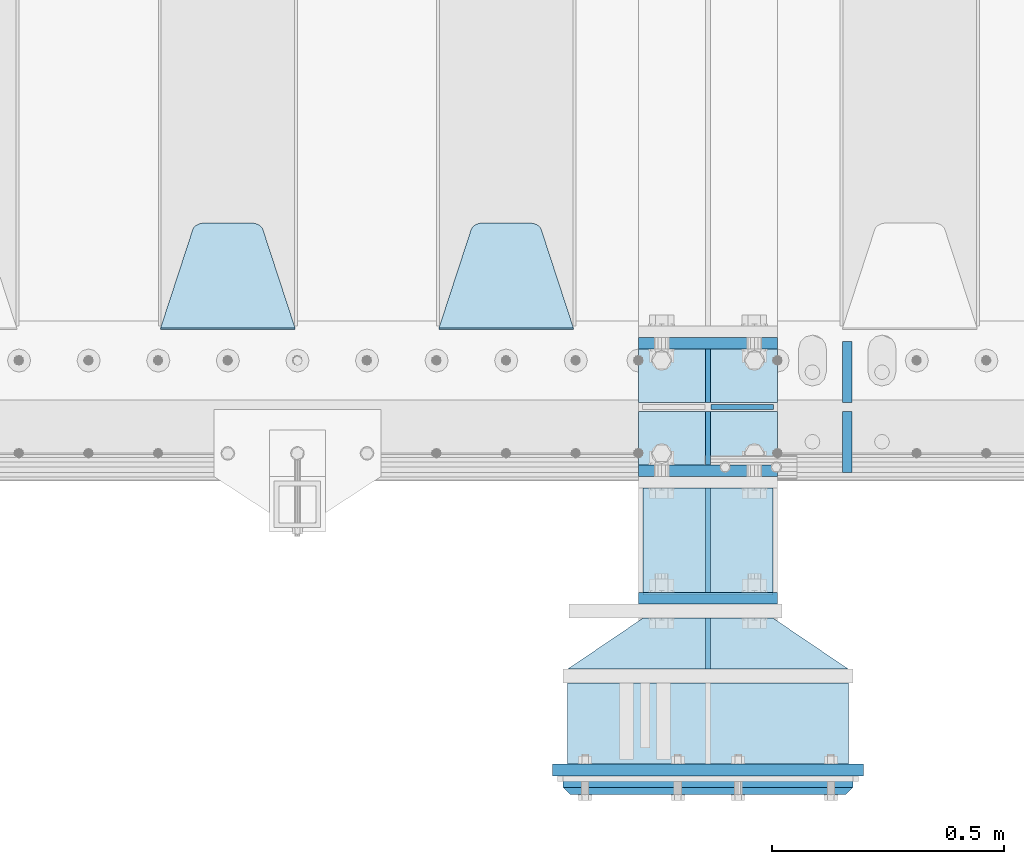
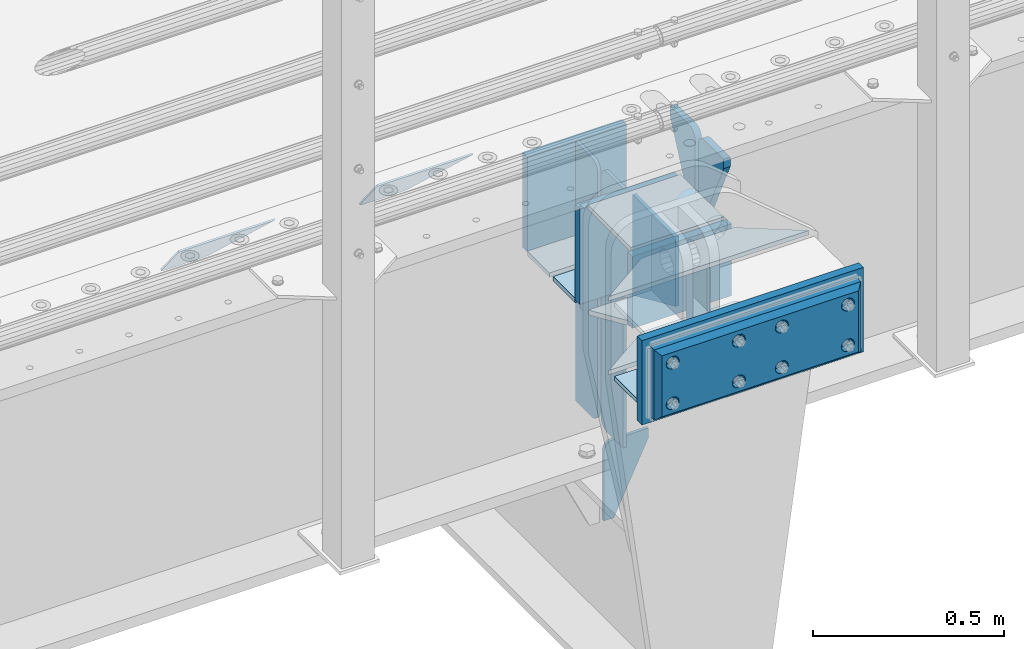
# One storey, part 208 of 242: 23 plates.
"""IFC2X3 building model written with IfcOpenShell, lengths in millimetres."""

from ifc_helpers import new_model, si_unit, frame, origin_with_axes, place, context, subcontext, project, spatial, faceted_brep, material, type_object, element, save


model = new_model("IFC2X3")

# Units and contexts
model_context = context("Model", 3, precision=1e-05, world=origin_with_axes())
body_context = subcontext(model_context, "Body", "Model", "MODEL_VIEW")
ifc_project = project(units=[si_unit("LENGTHUNIT", "METRE", prefix="MILLI"), si_unit("AREAUNIT", "SQUARE_METRE"), si_unit("VOLUMEUNIT", "CUBIC_METRE"), si_unit("MASSUNIT", "GRAM", prefix="KILO"), si_unit("TIMEUNIT", "SECOND"), si_unit("PLANEANGLEUNIT", "RADIAN"), si_unit("SOLIDANGLEUNIT", "STERADIAN"), si_unit("THERMODYNAMICTEMPERATUREUNIT", "DEGREE_CELSIUS"), si_unit("LUMINOUSINTENSITYUNIT", "LUMEN")], contexts=[model_context])

# Site, building, storey
site_placement = place(None, origin_with_axes())
site = spatial("IfcSite", under=ifc_project, at=site_placement, CompositionType="ELEMENT")
building_placement = place(site_placement, origin_with_axes())
building = spatial("IfcBuilding", under=site, at=building_placement, Name="Standard", CompositionType="ELEMENT")
storey_placement = place(building_placement, origin_with_axes())
storey = spatial("IfcBuildingStorey", under=building, at=storey_placement, Name="Undefined", CompositionType="ELEMENT", Elevation=0.0)

# Plates
ifc_material_1 = material(Name="STEEL/S355N")
plate_type_1 = type_object("IfcPlateType", PredefinedType="NOTDEFINED")
plate_1_placement = place(storey_placement, frame((-28554.9999999412, -24175.0000000349, -17.0000182225592), z_axis=(0.0, -1.0, 0.0), x_axis=(1.0, 0.0, 0.0)))
element("IfcPlate", 1, at=plate_1_placement, inside=storey, type_object=plate_type_1, material=ifc_material_1, context=body_context, shape_type="Brep", body=[
    faceted_brep([(0.0, -7.0, 0.0), (0.0, -7.0, 225.0), (0.0, 7.0, 225.0), (0.0, 7.0, 0.0), (280.0, -7.0, 225.0), (280.0, 7.0, 225.0), (280.0, -7.0, 0.0), (280.0, 7.0, 0.0)], [[[0, 1, 2, 3]], [[1, 4, 5, 2]], [[4, 6, 7, 5]], [[6, 0, 3, 7]], [[5, 7, 3, 2]], [[6, 4, 1, 0]]]),
])
plate_type_2 = type_object("IfcPlateType", PredefinedType="NOTDEFINED")
plate_2_placement = place(storey_placement, frame((-28408.4999999409, -24000.0000000349, -925.000018222557), z_axis=(0.0, 0.0, -1.0), x_axis=(1.0, 0.0, 0.0)))
element("IfcPlate", 2, at=plate_2_placement, inside=storey, type_object=plate_type_2, material=ifc_material_1, context=body_context, shape_type="Brep", body=[
    faceted_brep([(0.0, -5.0, 27.0), (0.0, -5.0, 250.0), (0.0, 5.0, 250.0), (0.0, 5.0, 27.0), (30.0, -5.0, 250.0), (30.0, 5.0, 250.0), (135.0, -5.0, 30.0), (135.0, 5.0, 30.0), (135.0, -5.0, 0.0), (135.0, 5.0, 0.0), (27.0, -5.0, 0.0), (27.0, 5.0, 0.0), (22.3114992029914, -5.0, 0.410190668670339), (22.3114992029914, 5.0, 0.410190668670339), (17.7654561302079, -5.0, 1.62829923878041), (17.7654561302079, 5.0, 1.62829923878041), (13.5, -5.0, 3.61731409782021), (13.5, 5.0, 3.61731409782021), (9.64473453846222, -5.0, 6.31680003578765), (9.64473453846222, 5.0, 6.31680003578765), (6.31680003578731, -5.0, 9.64473453846347), (6.31680003578731, 5.0, 9.64473453846347), (3.61731409782078, -5.0, 13.5), (3.61731409782078, 5.0, 13.5), (1.62829923877871, -5.0, 17.765456130207), (1.62829923877871, 5.0, 17.765456130207), (0.410190668670111, -5.0, 22.3114992029929), (0.410190668670111, 5.0, 22.3114992029929)], [[[0, 1, 2, 3]], [[1, 4, 5, 2]], [[4, 6, 7, 5]], [[6, 8, 9, 7]], [[8, 10, 11, 9]], [[10, 12, 13, 11]], [[12, 14, 15, 13]], [[14, 16, 17, 15]], [[16, 18, 19, 17]], [[18, 20, 21, 19]], [[20, 22, 23, 21]], [[22, 24, 25, 23]], [[24, 26, 27, 25]], [[26, 0, 3, 27]], [[5, 7, 9, 11, 13, 15, 17, 19, 21, 23, 25, 27, 3, 2]], [[26, 24, 22, 20, 18, 16, 14, 12, 10, 8, 6, 4, 1, 0]]]),
])
plate_type_3 = type_object("IfcPlateType", PredefinedType="NOTDEFINED")
plate_3_placement = place(storey_placement, frame((-28554.9999999412, -24177.842969296, -352.396699063478), z_axis=(0.0, -0.913811548702731, 0.406138465867881), x_axis=(1.0, 0.0, 0.0)))
element("IfcPlate", 3, at=plate_3_placement, inside=storey, type_object=plate_type_3, material=ifc_material_1, context=body_context, shape_type="Brep", body=[
    faceted_brep([(0.0, -7.0, 0.0), (0.0, -6.99999999999909, 246.221450805666), (0.0, 6.99999999999909, 246.22145080566), (0.0, 7.0, 0.0), (280.0, -6.99999999999909, 246.221450805666), (280.0, 6.99999999999909, 246.22145080566), (280.0, -7.0, 0.0), (280.0, 7.0, 0.0)], [[[0, 1, 2, 3]], [[1, 4, 5, 2]], [[4, 6, 7, 5]], [[6, 0, 3, 7]], [[5, 7, 3, 2]], [[6, 4, 1, 0]]]),
])
ifc_material_2 = material()
plate_type_4 = type_object("IfcPlateType", PredefinedType="NOTDEFINED")
plate_4_placement = place(storey_placement, frame((-28112.4999999399, -24595.000000035, -253.000018222559), z_axis=(0.0, -1.0, 0.0), x_axis=(-1.0, 0.0, 0.0)))
element("IfcPlate", 4, at=plate_4_placement, inside=storey, type_object=plate_type_4, material=ifc_material_2, context=body_context, shape_type="Brep", body=[
    faceted_brep([(0.0, -7.0, 0.0), (0.0, -7.0, 175.0), (0.0, 7.0, 175.0), (0.0, 7.0, 0.0), (605.0, -7.0, 175.0), (605.0, 7.0, 175.0), (605.0, -7.0, 0.0), (605.0, 7.0, 0.0)], [[[0, 1, 2, 3]], [[1, 4, 5, 2]], [[4, 6, 7, 5]], [[6, 0, 3, 7]], [[5, 7, 3, 2]], [[6, 4, 1, 0]]]),
])
plate_type_5 = type_object("IfcPlateType", PredefinedType="NOTDEFINED")
for number, where, z_axis, x_axis in (
    (5, (-28565.0, -23862.5, -340.0), (0.0, 0.0, 1.0), (1.0, 0.0, 0.0)),
    (6, (-28565.0, -24137.5, -340.0), (0.0, 0.0, 1.0), (1.0, 0.0, 0.0)),
):
    element("IfcPlate", number, at=place(storey_placement, frame(where, z_axis=z_axis, x_axis=x_axis)), inside=storey, type_object=plate_type_5, material=ifc_material_1, context=body_context, shape_type="Brep", body=[
        faceted_brep([(0.0, -12.5, 0.0), (0.0, -12.5, 305.0), (0.0, 12.5, 305.0), (0.0, 12.5, 0.0), (300.0, -12.5, 305.0), (300.0, 12.5, 305.0), (300.0, -12.5, 0.0), (300.0, 12.5, 0.0)], [[[0, 1, 2, 3]], [[1, 4, 5, 2]], [[4, 6, 7, 5]], [[6, 0, 3, 7]], [[5, 7, 3, 2]], [[6, 4, 1, 0]]]),
    ])
plate_type_6 = type_object("IfcPlateType", PredefinedType="NOTDEFINED")
plate_5_placement = place(storey_placement, frame((-28414.9999999407, -24565.0000000349, -24.0000182225592), z_axis=(0.0, 0.0, -1.0), x_axis=(0.0, 1.0, 0.0)))
element("IfcPlate", 7, at=plate_5_placement, inside=storey, type_object=plate_type_6, material=ifc_material_1, context=body_context, shape_type="Brep", body=[
    faceted_brep([(0.0, -5.0, 0.0), (0.0, -5.0, 222.0), (0.0, 5.0, 222.0), (0.0, 5.0, 0.0), (110.0, -5.0, 222.0), (110.0, 5.0, 222.0), (110.0, -5.0, 0.0), (110.0, 5.0, 0.0)], [[[0, 1, 2, 3]], [[1, 4, 5, 2]], [[4, 6, 7, 5]], [[6, 0, 3, 7]], [[5, 7, 3, 2]], [[6, 4, 1, 0]]]),
])
plate_type_7 = type_object("IfcPlateType", PredefinedType="NOTDEFINED")
for number, where, z_axis, x_axis in (
    (8, (-28112.4999999399, -24565.000000035, -253.000018222559), (-0.560566412034006, -0.828109472050236, 0.0), (-0.828109472050236, 0.560566412034007, 0.0)),
    (9, (-28112.4999999399, -24565.000000035, -17.0000182225592), (-0.560566412034006, -0.828109472050236, 0.0), (-0.828109472050236, 0.560566412034007, 0.0)),
):
    element("IfcPlate", number, at=place(storey_placement, frame(where, z_axis=z_axis, x_axis=x_axis)), inside=storey, type_object=plate_type_7, material=ifc_material_1, context=body_context, shape_type="Brep", body=[
        faceted_brep([(0.0, -7.0, 0.0), (501.006225585945, -7.0, 339.142669677734), (501.006225585945, 7.0, 339.142669677734), (0.0, 7.0, 0.0), (428.100738525391, -7.0, 156.958602905273), (428.100738525391, 7.0, 156.958602905273), (196.230087280281, -7.0, -4.00177668780088e-11), (196.230087280281, 7.0, -4.00177668780088e-11)], [[[0, 1, 2, 3]], [[1, 4, 5, 2]], [[4, 6, 7, 5]], [[6, 0, 3, 7]], [[5, 7, 3, 2]], [[6, 4, 1, 0]]]),
    ])
plate_type_8 = type_object("IfcPlateType", PredefinedType="NOTDEFINED")
plate_6_placement = place(storey_placement, frame((-28564.9999999411, -24412.5000000349, -250.000018222559), z_axis=(0.0, 0.0, 1.0), x_axis=(1.0, 0.0, 0.0)))
element("IfcPlate", 10, at=plate_6_placement, inside=storey, type_object=plate_type_8, material=ifc_material_1, context=body_context, shape_type="Brep", body=[
    faceted_brep([(0.0, -12.5, 0.0), (0.0, -12.5, 230.0), (0.0, 12.5, 230.0), (0.0, 12.5, 0.0), (300.0, -12.5, 230.0), (300.0, 12.5, 230.0), (300.0, -12.5, 0.0), (300.0, 12.5, 0.0)], [[[0, 1, 2, 3]], [[1, 4, 5, 2]], [[4, 6, 7, 5]], [[6, 0, 3, 7]], [[5, 7, 3, 2]], [[6, 4, 1, 0]]]),
])
ifc_material_3 = material()
plate_type_9 = type_object("IfcPlateType", PredefinedType="NOTDEFINED")
plate_7_placement = place(storey_placement, frame((-28102.4999999398, -24815.000000035, -22.5000182225592), z_axis=(0.0, 0.0, -1.0), x_axis=(-1.0, 0.0, 0.0)))
element("IfcPlate", 11, at=plate_7_placement, inside=storey, type_object=plate_type_9, material=ifc_material_3, context=body_context, shape_type="Brep", body=[
    faceted_brep([(0.0, -5.0, 0.0), (15.0, -20.0, 15.0), (15.0, -20.0, 210.0), (0.0, -5.0, 225.0), (625.0, -5.0, 225.0), (610.0, -20.0, 210.0), (610.0, -20.0, 15.0), (625.0, -5.0, 0.0), (625.0, 15.0, 0.0), (620.0, 20.0, 5.0), (620.0, 20.0, 220.0), (625.0, 15.0, 225.0), (0.0, 15.0, 225.0), (5.0, 20.0, 220.0), (5.0, 20.0, 5.0), (0.0, 15.0, 0.0), (30.179491924413, 5.00000000001455, 37.4999999999982), (37.5000000001019, 5.00000000001455, 30.1794919243094), (47.5000000001019, 5.00000000001455, 27.4999999999982), (57.5000000001019, 5.00000000001455, 30.1794919243094), (64.8205080757907, 5.00000000001455, 37.4999999999982), (67.5000000001019, 5.00000000001455, 47.4999999999982), (64.8205080757907, 5.00000000001455, 57.4999999999982), (57.5000000001019, 5.00000000001455, 64.8205080756869), (47.5000000001019, 5.00000000001455, 67.4999999999982), (37.5000000001019, 5.00000000001455, 64.820508075687), (30.179491924413, 5.00000000001455, 57.4999999999982), (27.5000000001019, 5.00000000001455, 47.4999999999982), (37.5000000001019, -20.0, 30.1794919243094), (30.179491924413, -20.0, 37.4999999999982), (47.5000000001019, -20.0, 27.4999999999982), (57.5000000001019, -20.0, 30.1794919243094), (64.8205080757907, -20.0, 37.4999999999982), (67.5000000001019, -20.0, 47.4999999999982), (64.8205080757907, -20.0, 57.4999999999982), (57.5000000001019, -20.0, 64.8205080756869), (47.5000000001019, -20.0, 67.4999999999982), (37.5000000001019, -20.0, 64.820508075687), (30.179491924413, -20.0, 57.4999999999982), (27.5000000001019, -20.0, 47.4999999999982), (230.179491924951, 5.00000000008004, 37.4999999999982), (237.50000000064, 5.00000000008004, 30.1794919243094), (247.50000000064, 5.00000000008004, 27.4999999999982), (257.50000000064, 5.00000000008004, 30.1794919243094), (264.820508076329, 5.00000000008004, 37.4999999999982), (267.50000000064, 5.00000000008004, 47.4999999999982), (264.820508076329, 5.00000000008004, 57.4999999999982), (257.50000000064, 5.00000000008004, 64.8205080756869), (247.50000000064, 5.00000000008004, 67.4999999999982), (237.50000000064, 5.00000000008004, 64.820508075687), (230.179491924951, 5.00000000008004, 57.4999999999982), (227.50000000064, 5.00000000008004, 47.4999999999982), (230.179491924951, -20.0, 37.4999999999982), (227.50000000064, -20.0, 47.4999999999982), (237.50000000064, -20.0, 30.1794919243094), (247.50000000064, -20.0, 27.4999999999982), (257.50000000064, -20.0, 30.1794919243094), (264.820508076329, -20.0, 37.4999999999982), (267.50000000064, -20.0, 47.4999999999982), (264.820508076329, -20.0, 57.4999999999982), (257.50000000064, -20.0, 64.8205080756869), (247.50000000064, -20.0, 67.4999999999982), (237.50000000064, -20.0, 64.820508075687), (230.179491924951, -20.0, 57.4999999999982), (560.179491925839, 5.0000000001819, 37.4999999999982), (567.500000001528, 5.0000000001819, 30.1794919243094), (577.500000001528, 5.0000000001819, 27.4999999999982), (587.500000001528, 5.0000000001819, 30.1794919243094), (594.820508077217, 5.0000000001819, 37.4999999999982), (597.500000001528, 5.0000000001819, 47.4999999999982), (594.820508077217, 5.0000000001819, 57.4999999999982), (587.500000001528, 5.0000000001819, 64.8205080756869), (577.500000001528, 5.0000000001819, 67.4999999999982), (567.500000001528, 5.0000000001819, 64.820508075687), (560.179491925839, 5.0000000001819, 57.4999999999982), (557.500000001528, 5.0000000001819, 47.4999999999982), (560.179491925839, -20.0, 37.4999999999982), (557.500000001528, -20.0, 47.4999999999982), (567.500000001528, -20.0, 30.1794919243094), (577.500000001528, -20.0, 27.4999999999982), (587.500000001528, -20.0, 30.1794919243094), (594.820508077217, -20.0, 37.4999999999982), (597.500000001528, -20.0, 47.4999999999982), (594.820508077217, -20.0, 57.4999999999982), (587.500000001528, -20.0, 64.8205080756869), (577.500000001528, -20.0, 67.4999999999982), (567.500000001528, -20.0, 64.820508075687), (560.179491925839, -20.0, 57.4999999999982), (560.179491925839, 5.0000000001819, 167.499999999998), (567.500000001528, 5.0000000001819, 160.179491924309), (577.500000001528, 5.0000000001819, 157.499999999998), (587.500000001528, 5.0000000001819, 160.179491924309), (594.820508077217, 5.0000000001819, 167.499999999998), (597.500000001528, 5.0000000001819, 177.499999999998), (594.820508077217, 5.0000000001819, 187.499999999998), (587.500000001528, 5.0000000001819, 194.820508075687), (577.500000001528, 5.0000000001819, 197.499999999998), (567.500000001528, 5.0000000001819, 194.820508075687), (560.179491925839, 5.0000000001819, 187.499999999998), (557.500000001528, 5.0000000001819, 177.499999999998), (560.179491925839, -20.0, 167.499999999998), (557.500000001528, -20.0, 177.499999999998), (567.500000001528, -20.0, 160.179491924309), (577.500000001528, -20.0, 157.499999999998), (587.500000001528, -20.0, 160.179491924309), (594.820508077217, -20.0, 167.499999999998), (597.500000001528, -20.0, 177.499999999998), (594.820508077217, -20.0, 187.499999999998), (587.500000001528, -20.0, 194.820508075687), (577.500000001528, -20.0, 197.499999999998), (567.500000001528, -20.0, 194.820508075687), (560.179491925839, -20.0, 187.499999999998), (230.179491924951, 5.00000000008004, 167.499999999998), (237.50000000064, 5.00000000008004, 160.179491924309), (247.50000000064, 5.00000000008004, 157.499999999998), (257.50000000064, 5.00000000008004, 160.179491924309), (264.820508076329, 5.00000000008004, 167.499999999998), (267.50000000064, 5.00000000008004, 177.499999999998), (264.820508076329, 5.00000000008004, 187.499999999998), (257.50000000064, 5.00000000008004, 194.820508075687), (247.50000000064, 5.00000000008004, 197.499999999998), (237.50000000064, 5.00000000008004, 194.820508075687), (230.179491924951, 5.00000000008004, 187.499999999998), (227.50000000064, 5.00000000008004, 177.499999999998), (230.179491924951, -20.0, 167.499999999998), (227.50000000064, -20.0, 177.499999999998), (237.50000000064, -20.0, 160.179491924309), (247.50000000064, -20.0, 157.499999999998), (257.50000000064, -20.0, 160.179491924309), (264.820508076329, -20.0, 167.499999999998), (267.50000000064, -20.0, 177.499999999998), (264.820508076329, -20.0, 187.499999999998), (257.50000000064, -20.0, 194.820508075687), (247.50000000064, -20.0, 197.499999999998), (237.50000000064, -20.0, 194.820508075687), (230.179491924951, -20.0, 187.499999999998), (30.179491924413, 5.00000000001455, 167.499999999998), (37.5000000001019, 5.00000000001455, 160.179491924309), (47.5000000001019, 5.00000000001455, 157.499999999998), (57.5000000001019, 5.00000000001455, 160.179491924309), (64.8205080757907, 5.00000000001455, 167.499999999998), (67.5000000001019, 5.00000000001455, 177.499999999998), (64.8205080757907, 5.00000000001455, 187.499999999998), (57.5000000001019, 5.00000000001455, 194.820508075687), (47.5000000001019, 5.00000000001455, 197.499999999998), (37.5000000001019, 5.00000000001455, 194.820508075687), (30.179491924413, 5.00000000001455, 187.499999999998), (27.5000000001019, 5.00000000001455, 177.499999999998), (30.179491924413, -20.0, 167.499999999998), (27.5000000001019, -20.0, 177.499999999998), (37.5000000001019, -20.0, 160.179491924309), (47.5000000001019, -20.0, 157.499999999998), (57.5000000001019, -20.0, 160.179491924309), (64.8205080757907, -20.0, 167.499999999998), (67.5000000001019, -20.0, 177.499999999998), (64.8205080757907, -20.0, 187.499999999998), (57.5000000001019, -20.0, 194.820508075687), (47.5000000001019, -20.0, 197.499999999998), (37.5000000001019, -20.0, 194.820508075687), (30.179491924413, -20.0, 187.499999999998), (360.179491925301, 5.00000000012005, 167.499999999998), (367.50000000099, 5.00000000012005, 160.179491924309), (377.50000000099, 5.00000000012005, 157.499999999998), (387.50000000099, 5.00000000012005, 160.179491924309), (394.820508076678, 5.00000000012005, 167.499999999998), (397.50000000099, 5.00000000012005, 177.499999999998), (394.820508076678, 5.00000000012005, 187.499999999998), (387.50000000099, 5.00000000012005, 194.820508075687), (377.50000000099, 5.00000000012005, 197.499999999998), (367.50000000099, 5.00000000012005, 194.820508075687), (360.179491925301, 5.00000000012005, 187.499999999998), (357.50000000099, 5.00000000012005, 177.499999999998), (360.179491925301, -20.0, 167.499999999998), (357.50000000099, -20.0, 177.499999999998), (367.50000000099, -20.0, 160.179491924309), (377.50000000099, -20.0, 157.499999999998), (387.50000000099, -20.0, 160.179491924309), (394.820508076678, -20.0, 167.499999999998), (397.50000000099, -20.0, 177.499999999998), (394.820508076678, -20.0, 187.499999999998), (387.50000000099, -20.0, 194.820508075687), (377.50000000099, -20.0, 197.499999999998), (367.50000000099, -20.0, 194.820508075687), (360.179491925301, -20.0, 187.499999999998), (360.179491925301, 5.00000000012005, 37.4999999999982), (367.50000000099, 5.00000000012005, 30.1794919243094), (377.50000000099, 5.00000000012005, 27.4999999999982), (387.50000000099, 5.00000000012005, 30.1794919243094), (394.820508076678, 5.00000000012005, 37.4999999999982), (397.50000000099, 5.00000000012005, 47.4999999999982), (394.820508076678, 5.00000000012005, 57.4999999999982), (387.50000000099, 5.00000000012005, 64.8205080756869), (377.50000000099, 5.00000000012005, 67.4999999999982), (367.50000000099, 5.00000000012005, 64.820508075687), (360.179491925301, 5.00000000012005, 57.4999999999982), (357.50000000099, 5.00000000012005, 47.4999999999982), (360.179491925301, -20.0, 37.4999999999982), (357.50000000099, -20.0, 47.4999999999982), (367.50000000099, -20.0, 30.1794919243094), (377.50000000099, -20.0, 27.4999999999982), (387.50000000099, -20.0, 30.1794919243094), (394.820508076678, -20.0, 37.4999999999982), (397.50000000099, -20.0, 47.4999999999982), (394.820508076678, -20.0, 57.4999999999982), (387.50000000099, -20.0, 64.8205080756869), (377.50000000099, -20.0, 67.4999999999982), (367.50000000099, -20.0, 64.820508075687), (360.179491925301, -20.0, 57.4999999999982)], [[[0, 1, 2, 3]], [[4, 5, 6, 7]], [[8, 9, 10, 11]], [[12, 13, 14, 15]], [[15, 14, 9, 8]], [[5, 4, 3, 2]], [[13, 12, 11, 10]], [[7, 6, 1, 0]], [[16, 17, 18, 19, 20, 21, 22, 23, 24, 25, 26, 27]], [[28, 17, 16, 29]], [[30, 18, 17, 28]], [[31, 19, 18, 30]], [[32, 20, 19, 31]], [[33, 21, 20, 32]], [[34, 22, 21, 33]], [[35, 23, 22, 34]], [[36, 24, 23, 35]], [[37, 25, 24, 36]], [[38, 26, 25, 37]], [[39, 27, 26, 38]], [[29, 16, 27, 39]], [[11, 12, 3, 4]], [[8, 11, 4, 7]], [[7, 0, 15, 8]], [[14, 13, 10, 9]], [[12, 15, 0, 3]], [[40, 41, 42, 43, 44, 45, 46, 47, 48, 49, 50, 51]], [[52, 40, 51, 53]], [[54, 41, 40, 52]], [[55, 42, 41, 54]], [[56, 43, 42, 55]], [[57, 44, 43, 56]], [[58, 45, 44, 57]], [[59, 46, 45, 58]], [[60, 47, 46, 59]], [[61, 48, 47, 60]], [[62, 49, 48, 61]], [[63, 50, 49, 62]], [[53, 51, 50, 63]], [[64, 65, 66, 67, 68, 69, 70, 71, 72, 73, 74, 75]], [[76, 64, 75, 77]], [[78, 65, 64, 76]], [[79, 66, 65, 78]], [[80, 67, 66, 79]], [[81, 68, 67, 80]], [[82, 69, 68, 81]], [[83, 70, 69, 82]], [[84, 71, 70, 83]], [[85, 72, 71, 84]], [[86, 73, 72, 85]], [[87, 74, 73, 86]], [[77, 75, 74, 87]], [[88, 89, 90, 91, 92, 93, 94, 95, 96, 97, 98, 99]], [[100, 88, 99, 101]], [[102, 89, 88, 100]], [[103, 90, 89, 102]], [[104, 91, 90, 103]], [[105, 92, 91, 104]], [[106, 93, 92, 105]], [[107, 94, 93, 106]], [[108, 95, 94, 107]], [[109, 96, 95, 108]], [[110, 97, 96, 109]], [[111, 98, 97, 110]], [[101, 99, 98, 111]], [[112, 113, 114, 115, 116, 117, 118, 119, 120, 121, 122, 123]], [[124, 112, 123, 125]], [[126, 113, 112, 124]], [[127, 114, 113, 126]], [[128, 115, 114, 127]], [[129, 116, 115, 128]], [[130, 117, 116, 129]], [[131, 118, 117, 130]], [[132, 119, 118, 131]], [[133, 120, 119, 132]], [[134, 121, 120, 133]], [[135, 122, 121, 134]], [[125, 123, 122, 135]], [[136, 137, 138, 139, 140, 141, 142, 143, 144, 145, 146, 147]], [[148, 136, 147, 149]], [[150, 137, 136, 148]], [[151, 138, 137, 150]], [[152, 139, 138, 151]], [[153, 140, 139, 152]], [[154, 141, 140, 153]], [[155, 142, 141, 154]], [[156, 143, 142, 155]], [[157, 144, 143, 156]], [[158, 145, 144, 157]], [[159, 146, 145, 158]], [[149, 147, 146, 159]], [[160, 161, 162, 163, 164, 165, 166, 167, 168, 169, 170, 171]], [[172, 160, 171, 173]], [[174, 161, 160, 172]], [[175, 162, 161, 174]], [[176, 163, 162, 175]], [[177, 164, 163, 176]], [[178, 165, 164, 177]], [[179, 166, 165, 178]], [[180, 167, 166, 179]], [[181, 168, 167, 180]], [[182, 169, 168, 181]], [[183, 170, 169, 182]], [[173, 171, 170, 183]], [[184, 185, 186, 187, 188, 189, 190, 191, 192, 193, 194, 195]], [[196, 184, 195, 197]], [[198, 185, 184, 196]], [[199, 186, 185, 198]], [[200, 187, 186, 199]], [[201, 188, 187, 200]], [[202, 189, 188, 201]], [[203, 190, 189, 202]], [[204, 191, 190, 203]], [[205, 192, 191, 204]], [[206, 193, 192, 205]], [[207, 194, 193, 206]], [[197, 195, 194, 207]], [[6, 5, 2, 1], [37, 36, 35, 34, 33, 32, 31, 30, 28, 29, 39, 38], [206, 205, 204, 203, 202, 201, 200, 199, 198, 196, 197, 207], [182, 181, 180, 179, 178, 177, 176, 175, 174, 172, 173, 183], [158, 157, 156, 155, 154, 153, 152, 151, 150, 148, 149, 159], [134, 133, 132, 131, 130, 129, 128, 127, 126, 124, 125, 135], [110, 109, 108, 107, 106, 105, 104, 103, 102, 100, 101, 111], [86, 85, 84, 83, 82, 81, 80, 79, 78, 76, 77, 87], [62, 61, 60, 59, 58, 57, 56, 55, 54, 52, 53, 63]]]),
])
plate_type_10 = type_object("IfcPlateType", PredefinedType="NOTDEFINED")
plate_8_placement = place(storey_placement, frame((-28079.9999999397, -24782.5000000351, -1.82225592197938e-05), z_axis=(0.0, 0.0, -1.0), x_axis=(-1.0, 0.0, 0.0)))
element("IfcPlate", 12, at=plate_8_placement, inside=storey, type_object=plate_type_10, material=ifc_material_1, context=body_context, shape_type="Brep", body=[
    faceted_brep([(0.0, -12.5, 0.0), (0.0, -12.5, 270.0), (0.0, 12.5, 270.0), (0.0, 12.5, 0.0), (670.0, -12.5, 270.0), (670.0, 12.5, 270.0), (670.0, -12.5, 0.0), (670.0, 12.5, 0.0)], [[[0, 1, 2, 3]], [[1, 4, 5, 2]], [[4, 6, 7, 5]], [[6, 0, 3, 7]], [[5, 7, 3, 2]], [[6, 4, 1, 0]]]),
])
plate_type_11 = type_object("IfcPlateType", PredefinedType="NOTDEFINED")
plate_9_placement = place(storey_placement, frame((-28414.9999999408, -24175.0000000349, -346.000018222559), z_axis=(0.0, -1.0, 0.0), x_axis=(0.0, 0.0, 1.0)))
element("IfcPlate", 13, at=plate_9_placement, inside=storey, type_object=plate_type_11, material=ifc_material_1, context=body_context, shape_type="Brep", body=[
    faceted_brep([(0.0, -5.0, 0.0), (100.0, -5.0, 225.0), (100.0, 5.0, 225.0), (0.0, 5.0, 0.0), (322.0, -5.0, 225.0), (322.0, 5.0, 225.0), (322.0, -5.0, 0.0), (322.0, 5.0, 0.0)], [[[0, 1, 2, 3]], [[1, 4, 5, 2]], [[4, 6, 7, 5]], [[6, 0, 3, 7]], [[5, 7, 3, 2]], [[6, 4, 1, 0]]]),
])
plate_type_12 = type_object("IfcPlateType", PredefinedType="NOTDEFINED")
plate_10_placement = place(storey_placement, frame((-28705.0, -23831.767766953, -1.76776695296758), z_axis=(0.0, 0.707106781186547, -0.707106781186548), x_axis=(-1.0, 0.0, 0.0)))
element("IfcPlate", 14, at=plate_10_placement, inside=storey, type_object=plate_type_12, material=ifc_material_1, context=body_context, shape_type="Brep", body=[
    faceted_brep([(0.0, -2.5, 0.0), (69.345504679477, -2.50000000000182, 300.171731424829), (69.345504679477, 2.5, 300.171731424829), (0.0, 2.5, 0.0), (70.9274061199576, -2.5, 304.897442415398), (70.9274061199576, 2.5, 304.897442415398), (73.3818627772307, -2.5, 309.234538108525), (73.3818627772307, 2.50000000000182, 309.234538108529), (76.6187032999551, -2.5, 313.023683126101), (76.6187032999551, 2.50000000000182, 313.023683126103), (80.5190132704993, -2.5, 316.12567259537), (80.5190132704993, 2.5, 316.12567259537), (84.9395038596849, -2.5, 318.426546230474), (84.9395038596849, 2.50000000000182, 318.426546230476), (89.7177759439219, -2.49999999999818, 319.841774983273), (89.7177759439219, 2.50000000000182, 319.841774983273), (94.678286292652, -2.5, 320.319366455076), (94.678286292652, 2.5, 320.319366455076), (195.321713707348, -2.5, 320.319366455076), (195.321713707348, 2.5, 320.319366455076), (200.282224056078, -2.5, 319.841774983272), (200.282224056078, 2.50000000000182, 319.841774983273), (205.060496140315, -2.5, 318.426546230474), (205.060496140315, 2.49999999999818, 318.426546230474), (209.480986729501, -2.49999999999818, 316.12567259537), (209.480986729501, 2.5, 316.12567259537), (213.381296700045, -2.5, 313.023683126101), (213.381296700045, 2.49999999999818, 313.023683126101), (216.618137222769, -2.5, 309.234538108525), (216.618137222769, 2.5, 309.234538108523), (219.072593880042, -2.49999999999818, 304.897442415398), (219.072593880042, 2.50000000000182, 304.897442415398), (220.654495320523, -2.50000000000182, 300.171731424829), (220.654495320523, 2.5, 300.171731424829), (290.0, -2.5, 0.0), (290.0, 2.5, -1.81898940354586e-12)], [[[0, 1, 2, 3]], [[1, 4, 5, 2]], [[4, 6, 7, 5]], [[6, 8, 9, 7]], [[8, 10, 11, 9]], [[10, 12, 13, 11]], [[12, 14, 15, 13]], [[14, 16, 17, 15]], [[16, 18, 19, 17]], [[18, 20, 21, 19]], [[20, 22, 23, 21]], [[22, 24, 25, 23]], [[24, 26, 27, 25]], [[26, 28, 29, 27]], [[28, 30, 31, 29]], [[30, 32, 33, 31]], [[32, 34, 35, 33]], [[34, 0, 3, 35]], [[5, 7, 9, 11, 13, 15, 17, 19, 21, 23, 25, 27, 29, 31, 33, 35, 3, 2]], [[34, 32, 30, 28, 26, 24, 22, 20, 18, 16, 14, 12, 10, 8, 6, 4, 1, 0]]]),
])
plate_11_placement = place(storey_placement, frame((-29305.0, -23831.767766953, -1.76776695296758), z_axis=(0.0, 0.707106781186547, -0.707106781186548), x_axis=(-1.0, 0.0, 0.0)))
element("IfcPlate", 15, at=plate_11_placement, inside=storey, type_object=plate_type_12, material=ifc_material_1, context=body_context, shape_type="Brep", body=[
    faceted_brep([(0.0, -2.5, 0.0), (69.345504679477, -2.50000000000182, 300.171731424829), (69.345504679477, 2.5, 300.171731424829), (0.0, 2.5, 0.0), (70.9274061199576, -2.5, 304.897442415398), (70.9274061199576, 2.5, 304.897442415398), (73.3818627772307, -2.5, 309.234538108525), (73.3818627772307, 2.50000000000182, 309.234538108529), (76.6187032999551, -2.5, 313.023683126101), (76.6187032999551, 2.50000000000182, 313.023683126103), (80.5190132704993, -2.5, 316.12567259537), (80.5190132704993, 2.5, 316.12567259537), (84.9395038596849, -2.5, 318.426546230474), (84.9395038596849, 2.50000000000182, 318.426546230476), (89.7177759439219, -2.49999999999818, 319.841774983273), (89.7177759439219, 2.50000000000182, 319.841774983273), (94.678286292652, -2.5, 320.319366455076), (94.678286292652, 2.5, 320.319366455076), (195.321713707348, -2.5, 320.319366455076), (195.321713707348, 2.5, 320.319366455076), (200.282224056078, -2.5, 319.841774983272), (200.282224056078, 2.50000000000182, 319.841774983273), (205.060496140315, -2.5, 318.426546230474), (205.060496140315, 2.49999999999818, 318.426546230474), (209.480986729501, -2.49999999999818, 316.12567259537), (209.480986729501, 2.5, 316.12567259537), (213.381296700045, -2.5, 313.023683126101), (213.381296700045, 2.49999999999818, 313.023683126101), (216.618137222769, -2.5, 309.234538108525), (216.618137222769, 2.5, 309.234538108523), (219.072593880042, -2.49999999999818, 304.897442415398), (219.072593880042, 2.50000000000182, 304.897442415398), (220.654495320523, -2.50000000000182, 300.171731424829), (220.654495320523, 2.5, 300.171731424829), (290.0, -2.5, 0.0), (290.0, 2.5, -1.81898940354586e-12)], [[[0, 1, 2, 3]], [[1, 4, 5, 2]], [[4, 6, 7, 5]], [[6, 8, 9, 7]], [[8, 10, 11, 9]], [[10, 12, 13, 11]], [[12, 14, 15, 13]], [[14, 16, 17, 15]], [[16, 18, 19, 17]], [[18, 20, 21, 19]], [[20, 22, 23, 21]], [[22, 24, 25, 23]], [[24, 26, 27, 25]], [[26, 28, 29, 27]], [[28, 30, 31, 29]], [[30, 32, 33, 31]], [[32, 34, 35, 33]], [[34, 0, 3, 35]], [[5, 7, 9, 11, 13, 15, 17, 19, 21, 23, 25, 27, 29, 31, 33, 35, 3, 2]], [[34, 32, 30, 28, 26, 24, 22, 20, 18, 16, 14, 12, 10, 8, 6, 4, 1, 0]]]),
])
plate_type_13 = type_object("IfcPlateType", PredefinedType="NOTDEFINED")
for number, where, z_axis, x_axis in (
    (16, (-28565.0, -24009.25, -343.0), (0.0, -1.0, 0.0), (1.0, 0.0, 0.0)),
    (17, (-28565.0, -23990.75, -343.0), (0.0, 1.0, 0.0), (1.0, 0.0, 0.0)),
):
    element("IfcPlate", number, at=place(storey_placement, frame(where, z_axis=z_axis, x_axis=x_axis)), inside=storey, type_object=plate_type_13, material=ifc_material_1, context=body_context, shape_type="Brep", body=[
        faceted_brep([(0.0, -7.0, 0.0), (0.0, -7.0, 115.75), (0.0, 7.0, 115.75), (0.0, 7.0, 0.0), (300.0, -7.0, 115.75), (300.0, 7.0, 115.75), (300.0, -7.0, 0.0), (300.0, 7.0, 0.0)], [[[0, 1, 2, 3]], [[1, 4, 5, 2]], [[4, 6, 7, 5]], [[6, 0, 3, 7]], [[5, 7, 3, 2]], [[6, 4, 1, 0]]]),
    ])
plate_type_14 = type_object("IfcPlateType", PredefinedType="NOTDEFINED")
for number, where, z_axis, x_axis in (
    (18, (-28415.0, -24009.25, -350.0), (0.0, 0.0, -1.0), (0.0, -1.0, 0.0)),
    (19, (-28415.0, -23990.75, -350.0), (0.0, 0.0, -1.0), (0.0, 1.0, 0.0)),
):
    element("IfcPlate", number, at=place(storey_placement, frame(where, z_axis=z_axis, x_axis=x_axis)), inside=storey, type_object=plate_type_14, material=ifc_material_1, context=body_context, shape_type="Brep", body=[
        faceted_brep([(0.0, -5.0, 0.0), (0.0, -5.0, 485.0), (0.0, 5.0, 485.0), (0.0, 5.0, 0.0), (0.455767409632244, -5.0, 490.209445330008), (0.455767409632244, 5.0, 490.209445330008), (1.80922137642119, -5.0, 495.26060429977), (1.80922137642119, 5.0, 495.26060429977), (4.01923788646673, -5.0, 500.0), (4.01923788646673, 5.0, 500.0), (7.01866670642994, -5.0, 504.283628290596), (7.01866670642994, 5.0, 504.283628290596), (10.7163717094045, -5.0, 507.981333293569), (10.7163717094045, 5.0, 507.981333293569), (15.0, -5.0, 510.980762113533), (15.0, 5.0, 510.980762113533), (19.7393957002314, -5.0, 513.190778623577), (19.7393957002314, 5.0, 513.190778623577), (24.7905546699913, -5.0, 514.544232590366), (24.7905546699913, 5.0, 514.544232590366), (30.0, -5.0, 515.0), (30.0, 5.0, 515.0), (115.75, -5.0, 515.0), (115.75, 5.0, 515.0), (115.75, -5.0, 0.0), (115.75, 5.0, 0.0)], [[[0, 1, 2, 3]], [[1, 4, 5, 2]], [[4, 6, 7, 5]], [[6, 8, 9, 7]], [[8, 10, 11, 9]], [[10, 12, 13, 11]], [[12, 14, 15, 13]], [[14, 16, 17, 15]], [[16, 18, 19, 17]], [[18, 20, 21, 19]], [[20, 22, 23, 21]], [[22, 24, 25, 23]], [[24, 0, 3, 25]], [[5, 7, 9, 11, 13, 15, 17, 19, 21, 23, 25, 3, 2]], [[24, 22, 20, 18, 16, 14, 12, 10, 8, 6, 4, 1, 0]]]),
    ])
for number, where, z_axis, x_axis in (
    (20, (-28415.0, -23990.75, -35.0), (0.0, 0.0, -1.0), (0.0, 1.0, 0.0)),
    (21, (-28415.0, -24009.25, -35.0), (0.0, 0.0, -1.0), (0.0, -1.0, 0.0)),
):
    element("IfcPlate", number, at=place(storey_placement, frame(where, z_axis=z_axis, x_axis=x_axis)), inside=storey, type_object=plate_type_14, material=ifc_material_1, context=body_context, shape_type="Brep", body=[
        faceted_brep([(0.0, -5.0, 30.0), (0.0, -5.0, 301.0), (0.0, 5.0, 301.0), (0.0, 5.0, 30.0), (115.75, -5.0, 301.0), (115.75, 5.0, 301.0), (115.75, -5.0, 0.0), (115.75, 5.0, 0.0), (30.0, -5.0, 0.0), (30.0, 5.0, 0.0), (24.7905546699913, -5.0, 0.455767409633758), (24.7905546699913, 5.0, 0.455767409633758), (19.7393957002314, -5.0, 1.80922137642275), (19.7393957002314, 5.0, 1.80922137642275), (15.0, -5.0, 4.01923788646684), (15.0, 5.0, 4.01923788646684), (10.7163717094045, -5.0, 7.01866670643066), (10.7163717094045, 5.0, 7.01866670643066), (7.01866670642994, -5.0, 10.7163717094038), (7.01866670642994, 5.0, 10.7163717094038), (4.01923788646673, -5.0, 15.0), (4.01923788646673, 5.0, 15.0), (1.80922137642119, -5.0, 19.7393957002299), (1.80922137642119, 5.0, 19.7393957002299), (0.455767409632244, -5.0, 24.7905546699921), (0.455767409632244, 5.0, 24.7905546699921)], [[[0, 1, 2, 3]], [[1, 4, 5, 2]], [[4, 6, 7, 5]], [[6, 8, 9, 7]], [[8, 10, 11, 9]], [[10, 12, 13, 11]], [[12, 14, 15, 13]], [[14, 16, 17, 15]], [[16, 18, 19, 17]], [[18, 20, 21, 19]], [[20, 22, 23, 21]], [[22, 24, 25, 23]], [[24, 0, 3, 25]], [[5, 7, 9, 11, 13, 15, 17, 19, 21, 23, 25, 3, 2]], [[24, 22, 20, 18, 16, 14, 12, 10, 8, 6, 4, 1, 0]]]),
    ])
plate_type_15 = type_object("IfcPlateType", PredefinedType="NOTDEFINED")
for number, where, z_axis, x_axis in (
    (22, (-28115.0, -24141.25, -35.0), (0.0, 0.0, -1.0), (0.0, 1.0, 0.0)),
    (23, (-28115.0, -23858.75, -35.0), (0.0, 0.0, -1.0), (0.0, -1.0, 0.0)),
):
    element("IfcPlate", number, at=place(storey_placement, frame(where, z_axis=z_axis, x_axis=x_axis)), inside=storey, type_object=plate_type_15, material=ifc_material_1, context=body_context, shape_type="Brep", body=[
        faceted_brep([(0.0, -10.0, 0.0), (0.0, -10.0, 30.0), (0.0, 10.0, 30.0), (0.0, 10.0, 0.0), (102.0, -10.0, 250.0), (102.0, 10.0, 250.0), (132.0, -10.0, 250.0), (132.0, 10.0, 250.0), (132.0, -10.0, 30.0), (132.0, 10.0, 30.0), (131.544232590368, -10.0, 24.790554669992), (131.544232590368, 10.0, 24.790554669992), (130.190778623579, -10.0, 19.7393957002299), (130.190778623579, 10.0, 19.7393957002299), (127.980762113533, -10.0, 15.0), (127.980762113533, 10.0, 15.0), (124.98133329357, -10.0, 10.7163717094038), (124.98133329357, 10.0, 10.7163717094038), (121.283628290596, -10.0, 7.01866670643062), (121.283628290596, 10.0, 7.01866670643062), (117.0, -10.0, 4.01923788646684), (117.0, 10.0, 4.01923788646684), (112.260604299769, -10.0, 1.80922137642278), (112.260604299769, 10.0, 1.80922137642278), (107.209445330009, -10.0, 0.455767409633722), (107.209445330009, 10.0, 0.455767409633722), (102.0, -10.0, 0.0), (102.0, 10.0, 0.0)], [[[0, 1, 2, 3]], [[1, 4, 5, 2]], [[4, 6, 7, 5]], [[6, 8, 9, 7]], [[8, 10, 11, 9]], [[10, 12, 13, 11]], [[12, 14, 15, 13]], [[14, 16, 17, 15]], [[16, 18, 19, 17]], [[18, 20, 21, 19]], [[20, 22, 23, 21]], [[22, 24, 25, 23]], [[24, 26, 27, 25]], [[26, 0, 3, 27]], [[5, 7, 9, 11, 13, 15, 17, 19, 21, 23, 25, 27, 3, 2]], [[26, 24, 22, 20, 18, 16, 14, 12, 10, 8, 6, 4, 1, 0]]]),
    ])

save(model, "model.ifc")
